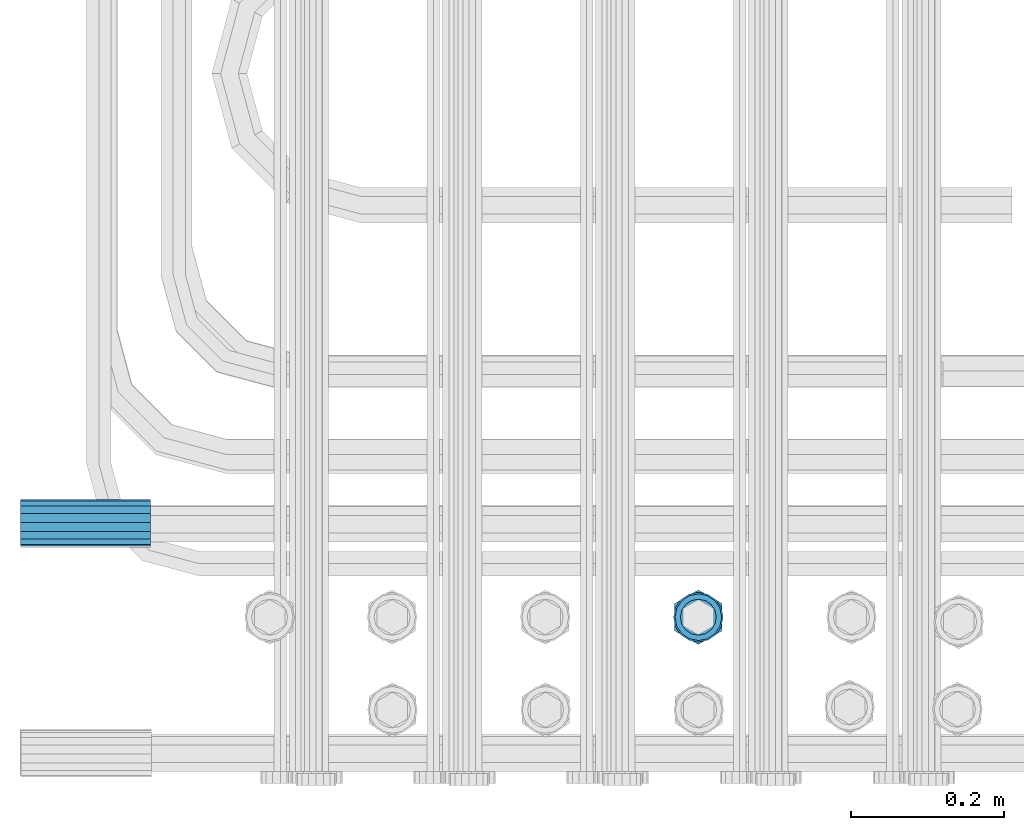
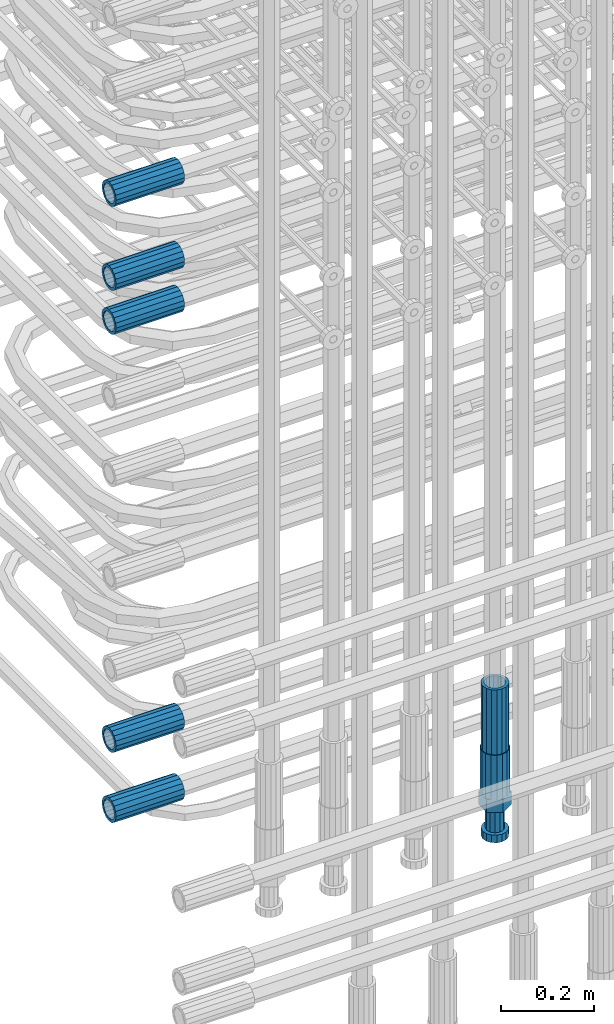
# One storey, part 32 of 177: 7 beams.
"""IFC2X3 building model written with IfcOpenShell, lengths in millimetres."""

from ifc_helpers import new_model, si_unit, frame, origin_with_axes, place, context, subcontext, project, spatial, faceted_brep, material, type_object, element, save


model = new_model("IFC2X3")

# Units and contexts
model_context_1 = context("Model", 3, precision=1e-05, world=origin_with_axes())
model_context_2 = context("Model", 3, precision=1e-05, world=origin_with_axes())
body_context = subcontext(model_context_2, "Body", "Model", "MODEL_VIEW")
ifc_project = project(units=[si_unit("LENGTHUNIT", "METRE", prefix="MILLI"), si_unit("AREAUNIT", "SQUARE_METRE"), si_unit("VOLUMEUNIT", "CUBIC_METRE"), si_unit("MASSUNIT", "GRAM", prefix="KILO"), si_unit("TIMEUNIT", "SECOND"), si_unit("PLANEANGLEUNIT", "RADIAN"), si_unit("SOLIDANGLEUNIT", "STERADIAN"), si_unit("THERMODYNAMICTEMPERATUREUNIT", "DEGREE_CELSIUS"), si_unit("LUMINOUSINTENSITYUNIT", "LUMEN")], contexts=[model_context_1])

# Site, building, storey
site_placement = place(None, origin_with_axes())
site = spatial("IfcSite", under=ifc_project, at=site_placement, CompositionType="ELEMENT")
building_placement = place(site_placement, origin_with_axes())
building = spatial("IfcBuilding", under=site, at=building_placement, Name="Undefined", CompositionType="ELEMENT")
storey_placement = place(building_placement, origin_with_axes())
storey = spatial("IfcBuildingStorey", under=building, at=storey_placement, Name="Undefined", CompositionType="ELEMENT", Elevation=0.0)

# Beams
ifc_material = material(Name="STEEL/S275")
beam_type_1 = type_object("IfcBeamType", PredefinedType="NOTDEFINED")
beam_1_placement = place(storey_placement, frame((2029920.00847313, 6205400.93588033, 20241.8883264263), z_axis=(0.0, 0.0, -1.0), x_axis=(-1.0, 0.0, 0.0)))
element("IfcBeam", 1, at=beam_1_placement, inside=storey, type_object=beam_type_1, material=ifc_material, Name="AG40N", context=body_context, shape_type="Brep", body=[
    faceted_brep([(0.0, -23.5000000001164, -9.31322574615479e-10), (0.0, -21.7111690140155, 8.99306066054851), (170.0, -21.7111690140155, 8.99306066054851), (170.0, -23.5, 0.0), (0.0, -16.6170093578839, 16.6170093575493), (170.0, -16.6170093578839, 16.6170093575493), (0.0, -8.99306066057943, 21.7111690137535), (170.0, -8.99306066057943, 21.7111690137535), (0.0, 1.16415321826935e-10, 23.5), (170.0, 0.0, 23.5), (0.0, 8.99306066057943, 21.7111690137535), (170.0, 8.99306066057943, 21.7111690137535), (0.0, 16.6170093578839, 16.6170093575493), (170.0, 16.6170093578839, 16.6170093575493), (0.0, 21.7111690140155, 8.99306066054851), (170.0, 21.7111690140155, 8.99306066054851), (0.0, 23.5000000001164, -9.31322574615479e-10), (170.0, 23.5, 0.0), (0.0, 21.7111690140155, -8.99306066054851), (170.0, 21.7111690140155, -8.99306066054851), (0.0, 16.6170093578839, -16.6170093575493), (170.0, 16.6170093578839, -16.6170093575493), (0.0, 8.99306066057943, -21.7111690137535), (170.0, 8.99306066057943, -21.7111690137535), (0.0, 1.16415321826935e-10, -23.5000000009313), (170.0, 0.0, -23.5), (0.0, -8.99306066057943, -21.7111690137535), (170.0, -8.99306066057943, -21.7111690137535), (0.0, -16.6170093578839, -16.6170093575493), (170.0, -16.6170093578839, -16.6170093575493), (0.0, -21.7111690140155, -8.99306066054851), (170.0, -21.7111690140155, -8.99306066054851), (0.0, -30.5, 0.0), (0.0, -28.1783257415937, -11.6718446873128), (170.0, -28.1783257415937, -11.6718446873128), (170.0, -30.5, 0.0), (0.0, -21.5667568261888, -21.5667568258941), (170.0, -21.5667568261888, -21.5667568258941), (0.0, -11.6718446871346, -28.1783257415518), (170.0, -11.6718446871346, -28.1783257415518), (0.0, 0.0, -30.5), (170.0, 0.0, -30.5), (0.0, 11.6718446871346, -28.1783257415518), (170.0, 11.6718446871346, -28.1783257415518), (0.0, 21.5667568261888, -21.5667568258941), (170.0, 21.5667568261888, -21.5667568258941), (0.0, 28.1783257415937, -11.6718446873128), (170.0, 28.1783257415937, -11.6718446873128), (0.0, 30.5, 0.0), (170.0, 30.5, 0.0), (0.0, 28.1783257415937, 11.6718446873128), (170.0, 28.1783257415937, 11.6718446873128), (0.0, 21.5667568261888, 21.5667568258941), (170.0, 21.5667568261888, 21.5667568258941), (0.0, 11.6718446871346, 28.1783257415518), (170.0, 11.6718446871346, 28.1783257415518), (0.0, 0.0, 30.5), (170.0, 0.0, 30.5), (0.0, -11.6718446871346, 28.1783257415518), (170.0, -11.6718446871346, 28.1783257415518), (0.0, -21.5667568261888, 21.5667568258941), (170.0, -21.5667568261888, 21.5667568258941), (0.0, -28.1783257415937, 11.6718446873128), (170.0, -28.1783257415937, 11.6718446873128)], [[[0, 1, 2, 3]], [[1, 4, 5, 2]], [[4, 6, 7, 5]], [[6, 8, 9, 7]], [[8, 10, 11, 9]], [[10, 12, 13, 11]], [[12, 14, 15, 13]], [[14, 16, 17, 15]], [[16, 18, 19, 17]], [[18, 20, 21, 19]], [[20, 22, 23, 21]], [[22, 24, 25, 23]], [[24, 26, 27, 25]], [[26, 28, 29, 27]], [[28, 30, 31, 29]], [[30, 0, 3, 31]], [[32, 33, 34, 35]], [[33, 36, 37, 34]], [[36, 38, 39, 37]], [[38, 40, 41, 39]], [[40, 42, 43, 41]], [[42, 44, 45, 43]], [[44, 46, 47, 45]], [[46, 48, 49, 47]], [[48, 50, 51, 49]], [[50, 52, 53, 51]], [[52, 54, 55, 53]], [[54, 56, 57, 55]], [[56, 58, 59, 57]], [[58, 60, 61, 59]], [[60, 62, 63, 61]], [[62, 32, 35, 63]], [[37, 39, 41, 43, 45, 47, 49, 51, 53, 55, 57, 59, 61, 63, 35, 34], [5, 7, 9, 11, 13, 15, 17, 19, 21, 23, 25, 27, 29, 31, 3, 2]], [[62, 60, 58, 56, 54, 52, 50, 48, 46, 44, 42, 40, 38, 36, 33, 32], [30, 28, 26, 24, 22, 20, 18, 16, 14, 12, 10, 8, 6, 4, 1, 0]]]),
])
beam_2_placement = place(storey_placement, frame((2029920.00847313, 6205400.93588033, 20356.8883264263), z_axis=(0.0, 0.0, -1.0), x_axis=(-1.0, 0.0, 0.0)))
element("IfcBeam", 2, at=beam_2_placement, inside=storey, type_object=beam_type_1, material=ifc_material, Name="AG40N", context=body_context, shape_type="Brep", body=[
    faceted_brep([(0.0, -23.5000000001164, -9.31322574615479e-10), (0.0, -21.7111690140155, 8.99306066054851), (170.0, -21.7111690140155, 8.99306066054851), (170.0, -23.5, 0.0), (0.0, -16.6170093578839, 16.6170093575493), (170.0, -16.6170093578839, 16.6170093575493), (0.0, -8.99306066057943, 21.7111690137535), (170.0, -8.99306066057943, 21.7111690137535), (0.0, 1.16415321826935e-10, 23.5), (170.0, 0.0, 23.5), (0.0, 8.99306066057943, 21.7111690137535), (170.0, 8.99306066057943, 21.7111690137535), (0.0, 16.6170093578839, 16.6170093575493), (170.0, 16.6170093578839, 16.6170093575493), (0.0, 21.7111690140155, 8.99306066054851), (170.0, 21.7111690140155, 8.99306066054851), (0.0, 23.5000000001164, -9.31322574615479e-10), (170.0, 23.5, 0.0), (0.0, 21.7111690140155, -8.99306066054851), (170.0, 21.7111690140155, -8.99306066054851), (0.0, 16.6170093578839, -16.6170093575493), (170.0, 16.6170093578839, -16.6170093575493), (0.0, 8.99306066057943, -21.7111690137535), (170.0, 8.99306066057943, -21.7111690137535), (0.0, 1.16415321826935e-10, -23.5000000009313), (170.0, 0.0, -23.5), (0.0, -8.99306066057943, -21.7111690137535), (170.0, -8.99306066057943, -21.7111690137535), (0.0, -16.6170093578839, -16.6170093575493), (170.0, -16.6170093578839, -16.6170093575493), (0.0, -21.7111690140155, -8.99306066054851), (170.0, -21.7111690140155, -8.99306066054851), (0.0, -30.5, 0.0), (0.0, -28.1783257415937, -11.6718446873128), (170.0, -28.1783257415937, -11.6718446873128), (170.0, -30.5, 0.0), (0.0, -21.5667568261888, -21.5667568258941), (170.0, -21.5667568261888, -21.5667568258941), (0.0, -11.6718446871346, -28.1783257415518), (170.0, -11.6718446871346, -28.1783257415518), (0.0, 0.0, -30.5), (170.0, 0.0, -30.5), (0.0, 11.6718446871346, -28.1783257415518), (170.0, 11.6718446871346, -28.1783257415518), (0.0, 21.5667568261888, -21.5667568258941), (170.0, 21.5667568261888, -21.5667568258941), (0.0, 28.1783257415937, -11.6718446873128), (170.0, 28.1783257415937, -11.6718446873128), (0.0, 30.5, 0.0), (170.0, 30.5, 0.0), (0.0, 28.1783257415937, 11.6718446873128), (170.0, 28.1783257415937, 11.6718446873128), (0.0, 21.5667568261888, 21.5667568258941), (170.0, 21.5667568261888, 21.5667568258941), (0.0, 11.6718446871346, 28.1783257415518), (170.0, 11.6718446871346, 28.1783257415518), (0.0, 0.0, 30.5), (170.0, 0.0, 30.5), (0.0, -11.6718446871346, 28.1783257415518), (170.0, -11.6718446871346, 28.1783257415518), (0.0, -21.5667568261888, 21.5667568258941), (170.0, -21.5667568261888, 21.5667568258941), (0.0, -28.1783257415937, 11.6718446873128), (170.0, -28.1783257415937, 11.6718446873128)], [[[0, 1, 2, 3]], [[1, 4, 5, 2]], [[4, 6, 7, 5]], [[6, 8, 9, 7]], [[8, 10, 11, 9]], [[10, 12, 13, 11]], [[12, 14, 15, 13]], [[14, 16, 17, 15]], [[16, 18, 19, 17]], [[18, 20, 21, 19]], [[20, 22, 23, 21]], [[22, 24, 25, 23]], [[24, 26, 27, 25]], [[26, 28, 29, 27]], [[28, 30, 31, 29]], [[30, 0, 3, 31]], [[32, 33, 34, 35]], [[33, 36, 37, 34]], [[36, 38, 39, 37]], [[38, 40, 41, 39]], [[40, 42, 43, 41]], [[42, 44, 45, 43]], [[44, 46, 47, 45]], [[46, 48, 49, 47]], [[48, 50, 51, 49]], [[50, 52, 53, 51]], [[52, 54, 55, 53]], [[54, 56, 57, 55]], [[56, 58, 59, 57]], [[58, 60, 61, 59]], [[60, 62, 63, 61]], [[62, 32, 35, 63]], [[37, 39, 41, 43, 45, 47, 49, 51, 53, 55, 57, 59, 61, 63, 35, 34], [5, 7, 9, 11, 13, 15, 17, 19, 21, 23, 25, 27, 29, 31, 3, 2]], [[62, 60, 58, 56, 54, 52, 50, 48, 46, 44, 42, 40, 38, 36, 33, 32], [30, 28, 26, 24, 22, 20, 18, 16, 14, 12, 10, 8, 6, 4, 1, 0]]]),
])
beam_3_placement = place(storey_placement, frame((2029920.00847313, 6205400.93588033, 20576.8883264264), z_axis=(0.0, 0.0, -1.0), x_axis=(-1.0, 0.0, 0.0)))
element("IfcBeam", 3, at=beam_3_placement, inside=storey, type_object=beam_type_1, material=ifc_material, Name="AG40N", context=body_context, shape_type="Brep", body=[
    faceted_brep([(0.0, -23.5000000001164, -9.31322574615479e-10), (0.0, -21.7111690140155, 8.99306066054851), (170.0, -21.7111690140155, 8.99306066054851), (170.0, -23.5, 0.0), (0.0, -16.6170093578839, 16.6170093575493), (170.0, -16.6170093578839, 16.6170093575493), (0.0, -8.99306066057943, 21.7111690137535), (170.0, -8.99306066057943, 21.7111690137535), (0.0, 1.16415321826935e-10, 23.5), (170.0, 0.0, 23.5), (0.0, 8.99306066057943, 21.7111690137535), (170.0, 8.99306066057943, 21.7111690137535), (0.0, 16.6170093578839, 16.6170093575493), (170.0, 16.6170093578839, 16.6170093575493), (0.0, 21.7111690140155, 8.99306066054851), (170.0, 21.7111690140155, 8.99306066054851), (0.0, 23.5000000001164, -9.31322574615479e-10), (170.0, 23.5, 0.0), (0.0, 21.7111690140155, -8.99306066054851), (170.0, 21.7111690140155, -8.99306066054851), (0.0, 16.6170093578839, -16.6170093575493), (170.0, 16.6170093578839, -16.6170093575493), (0.0, 8.99306066057943, -21.7111690137535), (170.0, 8.99306066057943, -21.7111690137535), (0.0, 1.16415321826935e-10, -23.5000000009313), (170.0, 0.0, -23.5), (0.0, -8.99306066057943, -21.7111690137535), (170.0, -8.99306066057943, -21.7111690137535), (0.0, -16.6170093578839, -16.6170093575493), (170.0, -16.6170093578839, -16.6170093575493), (0.0, -21.7111690140155, -8.99306066054851), (170.0, -21.7111690140155, -8.99306066054851), (0.0, -30.5, 0.0), (0.0, -28.1783257415937, -11.6718446873128), (170.0, -28.1783257415937, -11.6718446873128), (170.0, -30.5, 0.0), (0.0, -21.5667568261888, -21.5667568258941), (170.0, -21.5667568261888, -21.5667568258941), (0.0, -11.6718446871346, -28.1783257415518), (170.0, -11.6718446871346, -28.1783257415518), (0.0, 0.0, -30.5), (170.0, 0.0, -30.5), (0.0, 11.6718446871346, -28.1783257415518), (170.0, 11.6718446871346, -28.1783257415518), (0.0, 21.5667568261888, -21.5667568258941), (170.0, 21.5667568261888, -21.5667568258941), (0.0, 28.1783257415937, -11.6718446873128), (170.0, 28.1783257415937, -11.6718446873128), (0.0, 30.5, 0.0), (170.0, 30.5, 0.0), (0.0, 28.1783257415937, 11.6718446873128), (170.0, 28.1783257415937, 11.6718446873128), (0.0, 21.5667568261888, 21.5667568258941), (170.0, 21.5667568261888, 21.5667568258941), (0.0, 11.6718446871346, 28.1783257415518), (170.0, 11.6718446871346, 28.1783257415518), (0.0, 0.0, 30.5), (170.0, 0.0, 30.5), (0.0, -11.6718446871346, 28.1783257415518), (170.0, -11.6718446871346, 28.1783257415518), (0.0, -21.5667568261888, 21.5667568258941), (170.0, -21.5667568261888, 21.5667568258941), (0.0, -28.1783257415937, 11.6718446873128), (170.0, -28.1783257415937, 11.6718446873128)], [[[0, 1, 2, 3]], [[1, 4, 5, 2]], [[4, 6, 7, 5]], [[6, 8, 9, 7]], [[8, 10, 11, 9]], [[10, 12, 13, 11]], [[12, 14, 15, 13]], [[14, 16, 17, 15]], [[16, 18, 19, 17]], [[18, 20, 21, 19]], [[20, 22, 23, 21]], [[22, 24, 25, 23]], [[24, 26, 27, 25]], [[26, 28, 29, 27]], [[28, 30, 31, 29]], [[30, 0, 3, 31]], [[32, 33, 34, 35]], [[33, 36, 37, 34]], [[36, 38, 39, 37]], [[38, 40, 41, 39]], [[40, 42, 43, 41]], [[42, 44, 45, 43]], [[44, 46, 47, 45]], [[46, 48, 49, 47]], [[48, 50, 51, 49]], [[50, 52, 53, 51]], [[52, 54, 55, 53]], [[54, 56, 57, 55]], [[56, 58, 59, 57]], [[58, 60, 61, 59]], [[60, 62, 63, 61]], [[62, 32, 35, 63]], [[37, 39, 41, 43, 45, 47, 49, 51, 53, 55, 57, 59, 61, 63, 35, 34], [5, 7, 9, 11, 13, 15, 17, 19, 21, 23, 25, 27, 29, 31, 3, 2]], [[62, 60, 58, 56, 54, 52, 50, 48, 46, 44, 42, 40, 38, 36, 33, 32], [30, 28, 26, 24, 22, 20, 18, 16, 14, 12, 10, 8, 6, 4, 1, 0]]]),
])
beam_4_placement = place(storey_placement, frame((2029920.00847313, 6205400.93588033, 18961.9883264263), z_axis=(0.0, 0.0, -1.0), x_axis=(-1.0, 0.0, 0.0)))
element("IfcBeam", 4, at=beam_4_placement, inside=storey, type_object=beam_type_1, material=ifc_material, Name="AG40N", context=body_context, shape_type="Brep", body=[
    faceted_brep([(0.0, -23.5000000001164, -9.31322574615479e-10), (0.0, -21.7111690140155, 8.99306066054851), (170.0, -21.7111690140155, 8.99306066054851), (170.0, -23.5, 0.0), (0.0, -16.6170093578839, 16.6170093575493), (170.0, -16.6170093578839, 16.6170093575493), (0.0, -8.99306066057943, 21.7111690137535), (170.0, -8.99306066057943, 21.7111690137535), (0.0, 1.16415321826935e-10, 23.5), (170.0, 0.0, 23.5), (0.0, 8.99306066057943, 21.7111690137535), (170.0, 8.99306066057943, 21.7111690137535), (0.0, 16.6170093578839, 16.6170093575493), (170.0, 16.6170093578839, 16.6170093575493), (0.0, 21.7111690140155, 8.99306066054851), (170.0, 21.7111690140155, 8.99306066054851), (0.0, 23.5000000001164, -9.31322574615479e-10), (170.0, 23.5, 0.0), (0.0, 21.7111690140155, -8.99306066054851), (170.0, 21.7111690140155, -8.99306066054851), (0.0, 16.6170093578839, -16.6170093575493), (170.0, 16.6170093578839, -16.6170093575493), (0.0, 8.99306066057943, -21.7111690137535), (170.0, 8.99306066057943, -21.7111690137535), (0.0, 1.16415321826935e-10, -23.5000000009313), (170.0, 0.0, -23.5), (0.0, -8.99306066057943, -21.7111690137535), (170.0, -8.99306066057943, -21.7111690137535), (0.0, -16.6170093578839, -16.6170093575493), (170.0, -16.6170093578839, -16.6170093575493), (0.0, -21.7111690140155, -8.99306066054851), (170.0, -21.7111690140155, -8.99306066054851), (0.0, -30.5, 0.0), (0.0, -28.1783257415937, -11.6718446873128), (170.0, -28.1783257415937, -11.6718446873128), (170.0, -30.5, 0.0), (0.0, -21.5667568261888, -21.5667568258941), (170.0, -21.5667568261888, -21.5667568258941), (0.0, -11.6718446871346, -28.1783257415518), (170.0, -11.6718446871346, -28.1783257415518), (0.0, 0.0, -30.5), (170.0, 0.0, -30.5), (0.0, 11.6718446871346, -28.1783257415518), (170.0, 11.6718446871346, -28.1783257415518), (0.0, 21.5667568261888, -21.5667568258941), (170.0, 21.5667568261888, -21.5667568258941), (0.0, 28.1783257415937, -11.6718446873128), (170.0, 28.1783257415937, -11.6718446873128), (0.0, 30.5, 0.0), (170.0, 30.5, 0.0), (0.0, 28.1783257415937, 11.6718446873128), (170.0, 28.1783257415937, 11.6718446873128), (0.0, 21.5667568261888, 21.5667568258941), (170.0, 21.5667568261888, 21.5667568258941), (0.0, 11.6718446871346, 28.1783257415518), (170.0, 11.6718446871346, 28.1783257415518), (0.0, 0.0, 30.5), (170.0, 0.0, 30.5), (0.0, -11.6718446871346, 28.1783257415518), (170.0, -11.6718446871346, 28.1783257415518), (0.0, -21.5667568261888, 21.5667568258941), (170.0, -21.5667568261888, 21.5667568258941), (0.0, -28.1783257415937, 11.6718446873128), (170.0, -28.1783257415937, 11.6718446873128)], [[[0, 1, 2, 3]], [[1, 4, 5, 2]], [[4, 6, 7, 5]], [[6, 8, 9, 7]], [[8, 10, 11, 9]], [[10, 12, 13, 11]], [[12, 14, 15, 13]], [[14, 16, 17, 15]], [[16, 18, 19, 17]], [[18, 20, 21, 19]], [[20, 22, 23, 21]], [[22, 24, 25, 23]], [[24, 26, 27, 25]], [[26, 28, 29, 27]], [[28, 30, 31, 29]], [[30, 0, 3, 31]], [[32, 33, 34, 35]], [[33, 36, 37, 34]], [[36, 38, 39, 37]], [[38, 40, 41, 39]], [[40, 42, 43, 41]], [[42, 44, 45, 43]], [[44, 46, 47, 45]], [[46, 48, 49, 47]], [[48, 50, 51, 49]], [[50, 52, 53, 51]], [[52, 54, 55, 53]], [[54, 56, 57, 55]], [[56, 58, 59, 57]], [[58, 60, 61, 59]], [[60, 62, 63, 61]], [[62, 32, 35, 63]], [[37, 39, 41, 43, 45, 47, 49, 51, 53, 55, 57, 59, 61, 63, 35, 34], [5, 7, 9, 11, 13, 15, 17, 19, 21, 23, 25, 27, 29, 31, 3, 2]], [[62, 60, 58, 56, 54, 52, 50, 48, 46, 44, 42, 40, 38, 36, 33, 32], [30, 28, 26, 24, 22, 20, 18, 16, 14, 12, 10, 8, 6, 4, 1, 0]]]),
])
beam_5_placement = place(storey_placement, frame((2029920.00847313, 6205400.93588033, 19145.9883264264), z_axis=(0.0, 0.0, -1.0), x_axis=(-1.0, 0.0, 0.0)))
element("IfcBeam", 5, at=beam_5_placement, inside=storey, type_object=beam_type_1, material=ifc_material, Name="AG40N", context=body_context, shape_type="Brep", body=[
    faceted_brep([(0.0, -23.5000000001164, -9.31322574615479e-10), (0.0, -21.7111690140155, 8.99306066054851), (170.0, -21.7111690140155, 8.99306066054851), (170.0, -23.5, 0.0), (0.0, -16.6170093578839, 16.6170093575493), (170.0, -16.6170093578839, 16.6170093575493), (0.0, -8.99306066057943, 21.7111690137535), (170.0, -8.99306066057943, 21.7111690137535), (0.0, 1.16415321826935e-10, 23.5), (170.0, 0.0, 23.5), (0.0, 8.99306066057943, 21.7111690137535), (170.0, 8.99306066057943, 21.7111690137535), (0.0, 16.6170093578839, 16.6170093575493), (170.0, 16.6170093578839, 16.6170093575493), (0.0, 21.7111690140155, 8.99306066054851), (170.0, 21.7111690140155, 8.99306066054851), (0.0, 23.5000000001164, -9.31322574615479e-10), (170.0, 23.5, 0.0), (0.0, 21.7111690140155, -8.99306066054851), (170.0, 21.7111690140155, -8.99306066054851), (0.0, 16.6170093578839, -16.6170093575493), (170.0, 16.6170093578839, -16.6170093575493), (0.0, 8.99306066057943, -21.7111690137535), (170.0, 8.99306066057943, -21.7111690137535), (0.0, 1.16415321826935e-10, -23.5000000009313), (170.0, 0.0, -23.5), (0.0, -8.99306066057943, -21.7111690137535), (170.0, -8.99306066057943, -21.7111690137535), (0.0, -16.6170093578839, -16.6170093575493), (170.0, -16.6170093578839, -16.6170093575493), (0.0, -21.7111690140155, -8.99306066054851), (170.0, -21.7111690140155, -8.99306066054851), (0.0, -30.5, 0.0), (0.0, -28.1783257415937, -11.6718446873128), (170.0, -28.1783257415937, -11.6718446873128), (170.0, -30.5, 0.0), (0.0, -21.5667568261888, -21.5667568258941), (170.0, -21.5667568261888, -21.5667568258941), (0.0, -11.6718446871346, -28.1783257415518), (170.0, -11.6718446871346, -28.1783257415518), (0.0, 0.0, -30.5), (170.0, 0.0, -30.5), (0.0, 11.6718446871346, -28.1783257415518), (170.0, 11.6718446871346, -28.1783257415518), (0.0, 21.5667568261888, -21.5667568258941), (170.0, 21.5667568261888, -21.5667568258941), (0.0, 28.1783257415937, -11.6718446873128), (170.0, 28.1783257415937, -11.6718446873128), (0.0, 30.5, 0.0), (170.0, 30.5, 0.0), (0.0, 28.1783257415937, 11.6718446873128), (170.0, 28.1783257415937, 11.6718446873128), (0.0, 21.5667568261888, 21.5667568258941), (170.0, 21.5667568261888, 21.5667568258941), (0.0, 11.6718446871346, 28.1783257415518), (170.0, 11.6718446871346, 28.1783257415518), (0.0, 0.0, 30.5), (170.0, 0.0, 30.5), (0.0, -11.6718446871346, 28.1783257415518), (170.0, -11.6718446871346, 28.1783257415518), (0.0, -21.5667568261888, 21.5667568258941), (170.0, -21.5667568261888, 21.5667568258941), (0.0, -28.1783257415937, 11.6718446873128), (170.0, -28.1783257415937, 11.6718446873128)], [[[0, 1, 2, 3]], [[1, 4, 5, 2]], [[4, 6, 7, 5]], [[6, 8, 9, 7]], [[8, 10, 11, 9]], [[10, 12, 13, 11]], [[12, 14, 15, 13]], [[14, 16, 17, 15]], [[16, 18, 19, 17]], [[18, 20, 21, 19]], [[20, 22, 23, 21]], [[22, 24, 25, 23]], [[24, 26, 27, 25]], [[26, 28, 29, 27]], [[28, 30, 31, 29]], [[30, 0, 3, 31]], [[32, 33, 34, 35]], [[33, 36, 37, 34]], [[36, 38, 39, 37]], [[38, 40, 41, 39]], [[40, 42, 43, 41]], [[42, 44, 45, 43]], [[44, 46, 47, 45]], [[46, 48, 49, 47]], [[48, 50, 51, 49]], [[50, 52, 53, 51]], [[52, 54, 55, 53]], [[54, 56, 57, 55]], [[56, 58, 59, 57]], [[58, 60, 61, 59]], [[60, 62, 63, 61]], [[62, 32, 35, 63]], [[37, 39, 41, 43, 45, 47, 49, 51, 53, 55, 57, 59, 61, 63, 35, 34], [5, 7, 9, 11, 13, 15, 17, 19, 21, 23, 25, 27, 29, 31, 3, 2]], [[62, 60, 58, 56, 54, 52, 50, 48, 46, 44, 42, 40, 38, 36, 33, 32], [30, 28, 26, 24, 22, 20, 18, 16, 14, 12, 10, 8, 6, 4, 1, 0]]]),
])
beam_6_placement = place(storey_placement, frame((2030635.5030627, 6205277.49272666, 19060.966800425), z_axis=(-1.0, 0.0, 0.0), x_axis=(0.0, 0.0, -1.0)))
element("IfcBeam", 6, at=beam_6_placement, inside=storey, type_object=beam_type_1, material=ifc_material, Name="AG40N", context=body_context, shape_type="Brep", body=[
    faceted_brep([(0.0, -23.5000000001164, -9.31322574615479e-10), (0.0, -21.7111690140155, 8.99306066054851), (170.0, -21.7111690140155, 8.99306066054851), (170.0, -23.5, 0.0), (0.0, -16.6170093578839, 16.6170093575493), (170.0, -16.6170093578839, 16.6170093575493), (0.0, -8.99306066057943, 21.7111690137535), (170.0, -8.99306066057943, 21.7111690137535), (0.0, 1.16415321826935e-10, 23.5), (170.0, 0.0, 23.5), (0.0, 8.99306066057943, 21.7111690137535), (170.0, 8.99306066057943, 21.7111690137535), (0.0, 16.6170093578839, 16.6170093575493), (170.0, 16.6170093578839, 16.6170093575493), (0.0, 21.7111690140155, 8.99306066054851), (170.0, 21.7111690140155, 8.99306066054851), (0.0, 23.5000000001164, -9.31322574615479e-10), (170.0, 23.5, 0.0), (0.0, 21.7111690140155, -8.99306066054851), (170.0, 21.7111690140155, -8.99306066054851), (0.0, 16.6170093578839, -16.6170093575493), (170.0, 16.6170093578839, -16.6170093575493), (0.0, 8.99306066057943, -21.7111690137535), (170.0, 8.99306066057943, -21.7111690137535), (0.0, 1.16415321826935e-10, -23.5000000009313), (170.0, 0.0, -23.5), (0.0, -8.99306066057943, -21.7111690137535), (170.0, -8.99306066057943, -21.7111690137535), (0.0, -16.6170093578839, -16.6170093575493), (170.0, -16.6170093578839, -16.6170093575493), (0.0, -21.7111690140155, -8.99306066054851), (170.0, -21.7111690140155, -8.99306066054851), (0.0, -30.5, 0.0), (0.0, -28.1783257415937, -11.6718446873128), (170.0, -28.1783257415937, -11.6718446873128), (170.0, -30.5, 0.0), (0.0, -21.5667568261888, -21.5667568258941), (170.0, -21.5667568261888, -21.5667568258941), (0.0, -11.6718446871346, -28.1783257415518), (170.0, -11.6718446871346, -28.1783257415518), (0.0, 0.0, -30.5), (170.0, 0.0, -30.5), (0.0, 11.6718446871346, -28.1783257415518), (170.0, 11.6718446871346, -28.1783257415518), (0.0, 21.5667568261888, -21.5667568258941), (170.0, 21.5667568261888, -21.5667568258941), (0.0, 28.1783257415937, -11.6718446873128), (170.0, 28.1783257415937, -11.6718446873128), (0.0, 30.5, 0.0), (170.0, 30.5, 0.0), (0.0, 28.1783257415937, 11.6718446873128), (170.0, 28.1783257415937, 11.6718446873128), (0.0, 21.5667568261888, 21.5667568258941), (170.0, 21.5667568261888, 21.5667568258941), (0.0, 11.6718446871346, 28.1783257415518), (170.0, 11.6718446871346, 28.1783257415518), (0.0, 0.0, 30.5), (170.0, 0.0, 30.5), (0.0, -11.6718446871346, 28.1783257415518), (170.0, -11.6718446871346, 28.1783257415518), (0.0, -21.5667568261888, 21.5667568258941), (170.0, -21.5667568261888, 21.5667568258941), (0.0, -28.1783257415937, 11.6718446873128), (170.0, -28.1783257415937, 11.6718446873128)], [[[0, 1, 2, 3]], [[1, 4, 5, 2]], [[4, 6, 7, 5]], [[6, 8, 9, 7]], [[8, 10, 11, 9]], [[10, 12, 13, 11]], [[12, 14, 15, 13]], [[14, 16, 17, 15]], [[16, 18, 19, 17]], [[18, 20, 21, 19]], [[20, 22, 23, 21]], [[22, 24, 25, 23]], [[24, 26, 27, 25]], [[26, 28, 29, 27]], [[28, 30, 31, 29]], [[30, 0, 3, 31]], [[32, 33, 34, 35]], [[33, 36, 37, 34]], [[36, 38, 39, 37]], [[38, 40, 41, 39]], [[40, 42, 43, 41]], [[42, 44, 45, 43]], [[44, 46, 47, 45]], [[46, 48, 49, 47]], [[48, 50, 51, 49]], [[50, 52, 53, 51]], [[52, 54, 55, 53]], [[54, 56, 57, 55]], [[56, 58, 59, 57]], [[58, 60, 61, 59]], [[60, 62, 63, 61]], [[62, 32, 35, 63]], [[37, 39, 41, 43, 45, 47, 49, 51, 53, 55, 57, 59, 61, 63, 35, 34], [5, 7, 9, 11, 13, 15, 17, 19, 21, 23, 25, 27, 29, 31, 3, 2]], [[62, 60, 58, 56, 54, 52, 50, 48, 46, 44, 42, 40, 38, 36, 33, 32], [30, 28, 26, 24, 22, 20, 18, 16, 14, 12, 10, 8, 6, 4, 1, 0]]]),
])
beam_type_2 = type_object("IfcBeamType", Name="ROD65", PredefinedType="NOTDEFINED")
beam_7_placement = place(storey_placement, frame((2030635.50306269, 6205277.49272666, 18890.966800425), z_axis=(-1.0, 0.0, 0.0), x_axis=(0.0, 0.0, -1.0)))
element("IfcBeam", 7, at=beam_7_placement, inside=storey, type_object=beam_type_2, material=ifc_material, Name="AGB40", ObjectType="ROD65", context=body_context, shape_type="Brep", body=[
    faceted_brep([(117.0, 8.17543110251427, 30.873805644922), (117.0, 17.8250000001863, 30.873805644922), (117.0, 22.0056958701462, 23.6326279877685), (117.0, 12.4372115517035, 30.0260848065373), (117.0, -17.8250000001863, 30.873805644922), (150.200000000186, -17.8250000001863, 30.873805644922), (150.200000000186, 17.8250000001863, 30.873805644922), (117.0, -8.17543110251427, 30.873805644922), (117.0, -12.4372115517035, 30.0260848065373), (117.0, -22.0056958701462, 23.6326279877685), (117.0, -35.6500000003725, 0.0), (150.200000000186, -35.6500000003725, 0.0), (117.0, -30.8443150008097, 8.32369058486074), (117.0, -32.5, 0.0), (117.0, -30.8443150008097, -8.32369058462791), (117.0, -17.8250000001863, -30.873805644922), (150.200000000186, -17.8250000001863, -30.873805644922), (117.0, -22.0056958701462, -23.6326279877685), (117.0, -12.4372115517035, -30.0260848065373), (117.0, -8.17543110251427, -30.873805644922), (117.0, 17.8250000001863, -30.873805644922), (150.200000000186, 17.8250000001863, -30.873805644922), (117.0, 8.17543110251427, -30.873805644922), (117.0, 22.0056958701462, -23.6326279877685), (117.0, 12.4372115517035, -30.0260848065373), (117.0, 35.6500000003725, 0.0), (150.200000000186, 35.6500000003725, 0.0), (117.0, 30.8443150008097, -8.32369058486074), (117.0, 30.8443150008097, 8.32369058462791), (117.0, 32.5, 0.0), (0.0, -22.9809703892097, 22.9809703885621), (0.0, -30.0260848058388, 12.4372115518636), (117.0, -30.0260848067701, 12.4372115519363), (117.0, -22.9809703882784, 22.9809703885112), (-2.3283064365387e-10, 22.9809703892097, -22.9809703885639), (-4.65661287307739e-10, 30.0260848077014, -12.4372115518672), (117.0, 30.0260848067701, -12.4372115519363), (117.0, 22.9809703882784, -22.9809703885112), (-2.3283064365387e-10, -30.0260848067701, -12.4372115518672), (-2.3283064365387e-10, -22.9809703892097, -22.9809703885621), (117.0, -22.9809703882784, -22.9809703885112), (117.0, -30.0260848067701, -12.4372115519363), (-2.3283064365387e-10, -12.4372115507722, 30.0260848066137), (-2.3283064365387e-10, 9.31322574615479e-10, 32.4999999999982), (-2.3283064365387e-10, 12.4372115526348, 30.0260848066137), (0.0, 22.9809703892097, 22.9809703885621), (-2.3283064365387e-10, 30.0260848077014, 12.4372115518636), (-2.3283064365387e-10, 32.5, 0.0), (-2.3283064365387e-10, 12.4372115526348, -30.0260848066173), (-2.3283064365387e-10, 9.31322574615479e-10, -32.5), (-2.3283064365387e-10, -12.4372115517035, -30.0260848066173), (-4.65661287307739e-10, -32.4999999990687, -1.81898940354586e-12), (117.0, 22.9809703882784, 22.9809703885112), (117.0, 30.0260848067701, 12.4372115519363), (117.0, 0.0, -32.5), (117.0, 0.0, 32.5), (150.200000000186, 10.5, -18.1865334794857), (150.200000000186, 0.0, -21.0), (150.200000000186, -10.5, -18.1865334794857), (150.200000000186, -18.18653347902, -10.5), (150.200000000186, -21.0, 0.0), (150.200000000186, -18.18653347902, 10.5), (150.200000000186, -10.5, 18.1865334794857), (150.200000000186, 0.0, 21.0), (150.200000000186, 10.5, 18.1865334794857), (150.200000000186, 18.18653347902, 10.5), (150.200000000186, 21.0, 0.0), (150.200000000186, 18.18653347902, -10.5), (210.980000000447, -10.5, -18.1865334794857), (210.980000000447, 0.0, -21.0), (210.980000000447, -18.18653347902, -10.5), (210.980000000447, -21.0, 0.0), (210.980000000447, -18.18653347902, 10.5), (210.980000000447, -10.5, 18.1865334794857), (210.980000000447, 0.0, 21.0), (210.980000000447, 10.5, 18.1865334794857), (210.980000000447, 18.18653347902, 10.5), (210.980000000447, 21.0, 0.0), (210.980000000447, 18.18653347902, -10.5), (210.980000000447, 10.5, -18.1865334794857), (211.001368442696, -27.7269937992096, -11.491116326768), (211.003082550167, -21.2238094303757, -21.223815418547), (231.002518367059, -21.2131944671273, -21.2132004550658), (231.000804259587, -27.7163788359612, -11.4805013632867), (211.001368440451, -11.4911085031927, -27.7269970395137), (231.000804257343, -11.4804935399443, -27.7163820760325), (210.996487071217, -0.0106065049767494, -30.0106107392348), (230.995922888109, 8.45827162265778e-06, -29.9999957757536), (210.989181586672, 11.46989420522, -27.7269970329944), (230.988617403564, 11.4805091684684, -27.7163820695132), (210.980564180623, 21.2025914648548, -21.2238154064398), (230.979999997515, 21.2132064281031, -21.2132004429586), (210.971946775022, 27.7057703435421, -11.4911163107026), (230.971382591913, 27.7163853067905, -11.4805013472214), (210.96464129175, 29.9893808094785, -0.0106149562634528), (230.964077108642, 29.9999957727268, 7.21774995326996e-09), (210.959759924415, 27.7057638689876, 11.4698863970116), (230.959195741307, 27.7163788322359, 11.4805013604928), (210.958045816944, 21.2025795001537, 21.2025854887906), (230.957481633835, 21.213194463402, 21.2132004522718), (210.95975992666, 11.4698785729706, 27.7057671097573), (230.959195743551, 11.480493536219, 27.7163820732385), (210.964641295894, -0.010623425245285, 29.9893808094785), (230.964077112785, -8.46199691295624e-06, 29.9999957729597), (210.971946780439, -11.4911241354421, 27.705767103238), (230.97138259733, -11.4805091721937, 27.7163820667192), (210.980564186488, -21.2238213950768, 21.2025854766835), (230.980000003379, -21.2132064318284, 21.2132004401647), (210.989181592089, -27.7270002737641, 11.4698863809463), (230.988617408981, -27.7163853105158, 11.4805013444275), (210.996487075361, -30.0106107397005, -0.0106149734929204), (230.995922892253, -29.9999957764521, -1.00117176771164e-08)], [[[0, 1, 2, 3]], [[4, 5, 6, 1, 0, 7]], [[4, 7, 8, 9]], [[10, 11, 5, 4, 9, 12]], [[10, 12, 13, 14]], [[15, 16, 11, 10, 14, 17]], [[15, 17, 18, 19]], [[20, 21, 16, 15, 19, 22]], [[23, 20, 22, 24]], [[25, 26, 21, 20, 23, 27]], [[28, 25, 27, 29]], [[30, 31, 32, 33]], [[34, 35, 36, 37]], [[38, 39, 40, 41]], [[31, 30, 42, 43, 44, 45, 46, 47, 35, 34, 48, 49, 50, 39, 38, 51]], [[46, 45, 52, 53]], [[29, 47, 46, 53, 28]], [[27, 36, 35, 47, 29]], [[23, 37, 36, 27]], [[24, 48, 34, 37, 23]], [[22, 54, 49, 48, 24]], [[19, 54, 22]], [[18, 50, 49, 54, 19]], [[17, 40, 39, 50, 18]], [[14, 41, 40, 17]], [[13, 51, 38, 41, 14]], [[12, 32, 31, 51, 13]], [[9, 33, 32, 12]], [[8, 42, 30, 33, 9]], [[7, 55, 43, 42, 8]], [[0, 55, 7]], [[3, 44, 43, 55, 0]], [[2, 52, 45, 44, 3]], [[28, 53, 52, 2]], [[1, 6, 26, 25, 28, 2]], [[5, 11, 16, 21, 26, 6], [56, 57, 58, 59, 60, 61, 62, 63, 64, 65, 66, 67]], [[68, 58, 57, 69]], [[70, 59, 58, 68]], [[71, 60, 59, 70]], [[72, 61, 60, 71]], [[73, 62, 61, 72]], [[74, 63, 62, 73]], [[75, 64, 63, 74]], [[76, 65, 64, 75]], [[77, 66, 65, 76]], [[78, 67, 66, 77]], [[79, 56, 67, 78]], [[69, 57, 56, 79]], [[80, 81, 82, 83]], [[81, 84, 85, 82]], [[84, 86, 87, 85]], [[86, 88, 89, 87]], [[88, 90, 91, 89]], [[90, 92, 93, 91]], [[92, 94, 95, 93]], [[94, 96, 97, 95]], [[96, 98, 99, 97]], [[98, 100, 101, 99]], [[100, 102, 103, 101]], [[102, 104, 105, 103]], [[104, 106, 107, 105]], [[106, 108, 109, 107]], [[108, 110, 111, 109]], [[82, 85, 87, 89, 91, 93, 95, 97, 99, 101, 103, 105, 107, 109, 111, 83]], [[110, 80, 83, 111]], [[108, 106, 104, 102, 100, 98, 96, 94, 92, 90, 88, 86, 84, 81, 80, 110], [78, 77, 76, 75, 74, 73, 72, 71, 70, 68, 69, 79]]]),
])

save(model, "model.ifc")
